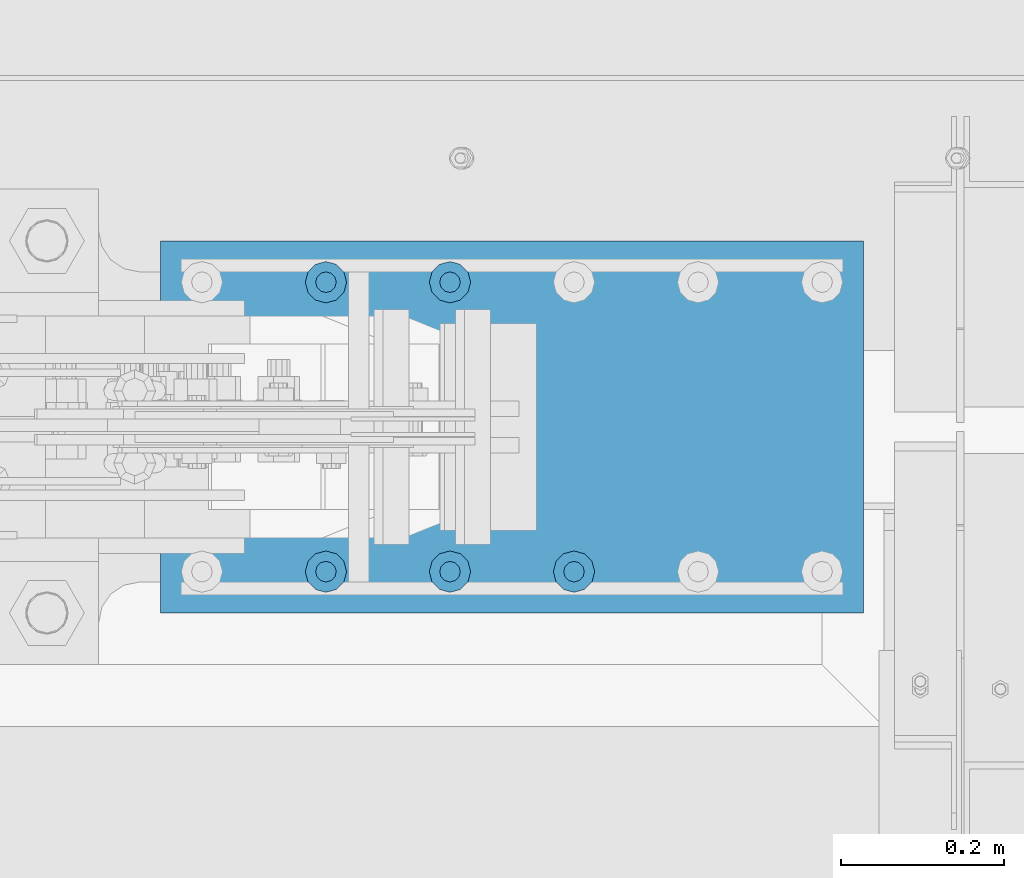
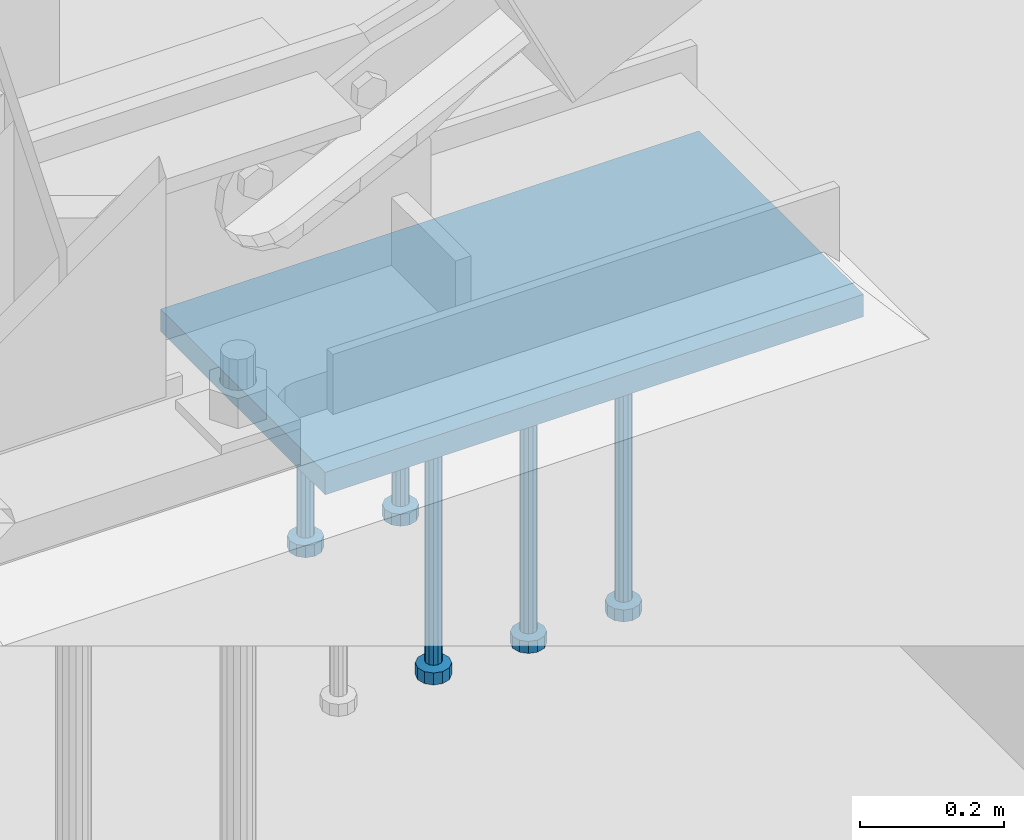
# One storey, part 890 of 1179: 6 beams, 1 element without a shape of its own.
"""IFC2X3 building model written with IfcOpenShell, lengths in millimetres."""

from ifc_helpers import new_model, si_unit, frame, origin_with_axes, place, context, subcontext, project, spatial, faceted_brep, material, type_object, element, aggregate, save


model = new_model("IFC2X3")

# Units and contexts
model_context = context("Model", 3, precision=1e-05, world=origin_with_axes())
body_context = subcontext(model_context, "Body", "Model", "MODEL_VIEW")
ifc_project = project(units=[si_unit("LENGTHUNIT", "METRE", prefix="MILLI"), si_unit("AREAUNIT", "SQUARE_METRE"), si_unit("VOLUMEUNIT", "CUBIC_METRE"), si_unit("MASSUNIT", "GRAM", prefix="KILO"), si_unit("TIMEUNIT", "SECOND"), si_unit("PLANEANGLEUNIT", "RADIAN"), si_unit("SOLIDANGLEUNIT", "STERADIAN"), si_unit("THERMODYNAMICTEMPERATUREUNIT", "DEGREE_CELSIUS"), si_unit("LUMINOUSINTENSITYUNIT", "LUMEN")], contexts=[model_context])

# Site, building, storey
site_placement = place(None, origin_with_axes())
site = spatial("IfcSite", under=ifc_project, at=site_placement, CompositionType="ELEMENT")
building_placement = place(site_placement, origin_with_axes())
building = spatial("IfcBuilding", under=site, at=building_placement, Name="Undefined", CompositionType="ELEMENT")
storey_placement = place(building_placement, origin_with_axes())
storey = spatial("IfcBuildingStorey", under=building, at=storey_placement, Name="Undefined", CompositionType="ELEMENT", Elevation=0.0)

# Assembly, beams
assembly_placement = place(storey_placement, origin_with_axes())
assembly = element("IfcElementAssembly", 1, at=assembly_placement, inside=storey, Name="EMBED_PLATE", AssemblyPlace="NOTDEFINED", PredefinedType="RIGID_FRAME")
ifc_material_1 = material(Name="STEEL/A108")
beam_type_1 = type_object("IfcBeamType", Name="STUD_1-DIA", PredefinedType="NOTDEFINED")
beam_1_placement = place(assembly_placement, frame((9004.3, 41376.6, -393.7), z_axis=(1.0, 0.0, 0.0), x_axis=(0.0, 0.0, -1.0)))
beam_1 = element("IfcBeam", 2, at=beam_1_placement, type_object=beam_type_1, material=ifc_material_1, Name="STUD", ObjectType="STUD_1-DIA", context=body_context, shape_type="Brep", body=[
    faceted_brep([(0.0, -12.7, 0.0), (0.0, -11.0, -6.34999990463257), (382.016, -11.0, -6.34999990463257), (382.016, -12.6999998092651, 0.0), (0.0, -6.34999990463257, -11.0), (382.016, -6.34999990463257, -11.0), (0.0, 0.0, -12.6999998092651), (382.016, 0.0, -12.6999998092651), (0.0, 6.34999990463257, -11.0), (382.016, 6.34999990463257, -11.0), (0.0, 11.0, -6.34999990463257), (382.016, 11.0, -6.34999990463257), (0.0, 12.7, 0.0), (382.016, 12.6999998092651, 0.0), (0.0, 11.0, 6.34999990463257), (382.016, 11.0, 6.34999990463257), (0.0, 6.34999990463257, 11.0), (382.016, 6.34999990463257, 11.0), (0.0, 0.0, 12.6999998092651), (382.016, 0.0, 12.6999998092651), (0.0, -6.34999990463257, 11.0), (382.016, -6.34999990463257, 11.0), (0.0, -11.0, 6.34999990463257), (382.016, -11.0, 6.34999990463257), (386.08, -22.0, -12.6999998092651), (386.08, -25.3999996185303, 0.0), (386.08, -12.6999998092651, -22.0), (386.08, 0.0, -25.3999996185303), (386.08, 12.6999998092651, -22.0), (386.08, 22.0, -12.6999998092651), (386.08, 25.3999996185303, 0.0), (386.08, 22.0, 12.6999998092651), (386.08, 12.6999998092651, 22.0), (386.08, 0.0, 25.3999996185303), (386.08, -12.6999998092651, 22.0), (386.08, -22.0, 12.6999998092651), (406.4, -22.0, -12.6999998092651), (406.4, -25.3999996185303, 0.0), (406.4, -12.6999998092651, -22.0), (406.4, 0.0, -25.3999996185303), (406.4, 12.6999998092651, -22.0), (406.4, 22.0, -12.6999998092651), (406.4, 25.3999996185303, 0.0), (406.4, 22.0, 12.6999998092651), (406.4, 12.6999998092651, 22.0), (406.4, 0.0, 25.3999996185303), (406.4, -12.6999998092651, 22.0), (406.4, -22.0, 12.6999998092651)], [[[0, 1, 2, 3]], [[1, 4, 5, 2]], [[4, 6, 7, 5]], [[6, 8, 9, 7]], [[8, 10, 11, 9]], [[10, 12, 13, 11]], [[12, 14, 15, 13]], [[14, 16, 17, 15]], [[16, 18, 19, 17]], [[18, 20, 21, 19]], [[20, 22, 23, 21]], [[22, 0, 3, 23]], [[22, 20, 18, 16, 14, 12, 10, 8, 6, 4, 1, 0]], [[3, 2, 24, 25]], [[2, 5, 26, 24]], [[5, 7, 27, 26]], [[7, 9, 28, 27]], [[9, 11, 29, 28]], [[11, 13, 30, 29]], [[13, 15, 31, 30]], [[15, 17, 32, 31]], [[17, 19, 33, 32]], [[19, 21, 34, 33]], [[21, 23, 35, 34]], [[23, 3, 25, 35]], [[25, 24, 36, 37]], [[24, 26, 38, 36]], [[26, 27, 39, 38]], [[27, 28, 40, 39]], [[28, 29, 41, 40]], [[29, 30, 42, 41]], [[30, 31, 43, 42]], [[31, 32, 44, 43]], [[32, 33, 45, 44]], [[33, 34, 46, 45]], [[34, 35, 47, 46]], [[35, 25, 37, 47]], [[38, 39, 40, 41, 42, 43, 44, 45, 46, 47, 37, 36]]]),
])
beam_2_placement = place(assembly_placement, frame((8851.9, 41376.6, -393.7), z_axis=(1.0, 0.0, 0.0), x_axis=(0.0, 0.0, -1.0)))
beam_2 = element("IfcBeam", 3, at=beam_2_placement, type_object=beam_type_1, material=ifc_material_1, Name="STUD", ObjectType="STUD_1-DIA", context=body_context, shape_type="Brep", body=[
    faceted_brep([(0.0, -12.7, 0.0), (0.0, -11.0, -6.34999990463257), (382.016, -11.0, -6.34999990463257), (382.016, -12.6999998092651, 0.0), (0.0, -6.34999990463257, -11.0), (382.016, -6.34999990463257, -11.0), (0.0, 0.0, -12.6999998092651), (382.016, 0.0, -12.6999998092651), (0.0, 6.34999990463257, -11.0), (382.016, 6.34999990463257, -11.0), (0.0, 11.0, -6.34999990463257), (382.016, 11.0, -6.34999990463257), (0.0, 12.7, 0.0), (382.016, 12.6999998092651, 0.0), (0.0, 11.0, 6.34999990463257), (382.016, 11.0, 6.34999990463257), (0.0, 6.34999990463257, 11.0), (382.016, 6.34999990463257, 11.0), (0.0, 0.0, 12.6999998092651), (382.016, 0.0, 12.6999998092651), (0.0, -6.34999990463257, 11.0), (382.016, -6.34999990463257, 11.0), (0.0, -11.0, 6.34999990463257), (382.016, -11.0, 6.34999990463257), (386.08, -22.0, -12.6999998092651), (386.08, -25.3999996185303, 0.0), (386.08, -12.6999998092651, -22.0), (386.08, 0.0, -25.3999996185303), (386.08, 12.6999998092651, -22.0), (386.08, 22.0, -12.6999998092651), (386.08, 25.3999996185303, 0.0), (386.08, 22.0, 12.6999998092651), (386.08, 12.6999998092651, 22.0), (386.08, 0.0, 25.3999996185303), (386.08, -12.6999998092651, 22.0), (386.08, -22.0, 12.6999998092651), (406.4, -22.0, -12.6999998092651), (406.4, -25.3999996185303, 0.0), (406.4, -12.6999998092651, -22.0), (406.4, 0.0, -25.3999996185303), (406.4, 12.6999998092651, -22.0), (406.4, 22.0, -12.6999998092651), (406.4, 25.3999996185303, 0.0), (406.4, 22.0, 12.6999998092651), (406.4, 12.6999998092651, 22.0), (406.4, 0.0, 25.3999996185303), (406.4, -12.6999998092651, 22.0), (406.4, -22.0, 12.6999998092651)], [[[0, 1, 2, 3]], [[1, 4, 5, 2]], [[4, 6, 7, 5]], [[6, 8, 9, 7]], [[8, 10, 11, 9]], [[10, 12, 13, 11]], [[12, 14, 15, 13]], [[14, 16, 17, 15]], [[16, 18, 19, 17]], [[18, 20, 21, 19]], [[20, 22, 23, 21]], [[22, 0, 3, 23]], [[22, 20, 18, 16, 14, 12, 10, 8, 6, 4, 1, 0]], [[3, 2, 24, 25]], [[2, 5, 26, 24]], [[5, 7, 27, 26]], [[7, 9, 28, 27]], [[9, 11, 29, 28]], [[11, 13, 30, 29]], [[13, 15, 31, 30]], [[15, 17, 32, 31]], [[17, 19, 33, 32]], [[19, 21, 34, 33]], [[21, 23, 35, 34]], [[23, 3, 25, 35]], [[25, 24, 36, 37]], [[24, 26, 38, 36]], [[26, 27, 39, 38]], [[27, 28, 40, 39]], [[28, 29, 41, 40]], [[29, 30, 42, 41]], [[30, 31, 43, 42]], [[31, 32, 44, 43]], [[32, 33, 45, 44]], [[33, 34, 46, 45]], [[34, 35, 47, 46]], [[35, 25, 37, 47]], [[38, 39, 40, 41, 42, 43, 44, 45, 46, 47, 37, 36]]]),
])
beam_3_placement = place(assembly_placement, frame((9156.7, 41021.0, -393.7), z_axis=(1.0, 0.0, 0.0), x_axis=(0.0, 0.0, -1.0)))
beam_3 = element("IfcBeam", 4, at=beam_3_placement, type_object=beam_type_1, material=ifc_material_1, Name="STUD", ObjectType="STUD_1-DIA", context=body_context, shape_type="Brep", body=[
    faceted_brep([(0.0, -12.7, 0.0), (0.0, -11.0, -6.34999990463257), (382.016, -11.0, -6.34999990463257), (382.016, -12.6999998092651, 0.0), (0.0, -6.34999990463257, -11.0), (382.016, -6.34999990463257, -11.0), (0.0, 0.0, -12.6999998092651), (382.016, 0.0, -12.6999998092651), (0.0, 6.34999990463257, -11.0), (382.016, 6.34999990463257, -11.0), (0.0, 11.0, -6.34999990463257), (382.016, 11.0, -6.34999990463257), (0.0, 12.7, 0.0), (382.016, 12.6999998092651, 0.0), (0.0, 11.0, 6.34999990463257), (382.016, 11.0, 6.34999990463257), (0.0, 6.34999990463257, 11.0), (382.016, 6.34999990463257, 11.0), (0.0, 0.0, 12.6999998092651), (382.016, 0.0, 12.6999998092651), (0.0, -6.34999990463257, 11.0), (382.016, -6.34999990463257, 11.0), (0.0, -11.0, 6.34999990463257), (382.016, -11.0, 6.34999990463257), (386.08, -22.0, -12.6999998092651), (386.08, -25.3999996185303, 0.0), (386.08, -12.6999998092651, -22.0), (386.08, 0.0, -25.3999996185303), (386.08, 12.6999998092651, -22.0), (386.08, 22.0, -12.6999998092651), (386.08, 25.3999996185303, 0.0), (386.08, 22.0, 12.6999998092651), (386.08, 12.6999998092651, 22.0), (386.08, 0.0, 25.3999996185303), (386.08, -12.6999998092651, 22.0), (386.08, -22.0, 12.6999998092651), (406.4, -22.0, -12.6999998092651), (406.4, -25.3999996185303, 0.0), (406.4, -12.6999998092651, -22.0), (406.4, 0.0, -25.3999996185303), (406.4, 12.6999998092651, -22.0), (406.4, 22.0, -12.6999998092651), (406.4, 25.3999996185303, 0.0), (406.4, 22.0, 12.6999998092651), (406.4, 12.6999998092651, 22.0), (406.4, 0.0, 25.3999996185303), (406.4, -12.6999998092651, 22.0), (406.4, -22.0, 12.6999998092651)], [[[0, 1, 2, 3]], [[1, 4, 5, 2]], [[4, 6, 7, 5]], [[6, 8, 9, 7]], [[8, 10, 11, 9]], [[10, 12, 13, 11]], [[12, 14, 15, 13]], [[14, 16, 17, 15]], [[16, 18, 19, 17]], [[18, 20, 21, 19]], [[20, 22, 23, 21]], [[22, 0, 3, 23]], [[22, 20, 18, 16, 14, 12, 10, 8, 6, 4, 1, 0]], [[3, 2, 24, 25]], [[2, 5, 26, 24]], [[5, 7, 27, 26]], [[7, 9, 28, 27]], [[9, 11, 29, 28]], [[11, 13, 30, 29]], [[13, 15, 31, 30]], [[15, 17, 32, 31]], [[17, 19, 33, 32]], [[19, 21, 34, 33]], [[21, 23, 35, 34]], [[23, 3, 25, 35]], [[25, 24, 36, 37]], [[24, 26, 38, 36]], [[26, 27, 39, 38]], [[27, 28, 40, 39]], [[28, 29, 41, 40]], [[29, 30, 42, 41]], [[30, 31, 43, 42]], [[31, 32, 44, 43]], [[32, 33, 45, 44]], [[33, 34, 46, 45]], [[34, 35, 47, 46]], [[35, 25, 37, 47]], [[38, 39, 40, 41, 42, 43, 44, 45, 46, 47, 37, 36]]]),
])
beam_4_placement = place(assembly_placement, frame((9004.3, 41021.0, -393.7), z_axis=(1.0, 0.0, 0.0), x_axis=(0.0, 0.0, -1.0)))
beam_4 = element("IfcBeam", 5, at=beam_4_placement, type_object=beam_type_1, material=ifc_material_1, Name="STUD", ObjectType="STUD_1-DIA", context=body_context, shape_type="Brep", body=[
    faceted_brep([(0.0, -12.7, 0.0), (0.0, -11.0, -6.34999990463257), (382.016, -11.0, -6.34999990463257), (382.016, -12.6999998092651, 0.0), (0.0, -6.34999990463257, -11.0), (382.016, -6.34999990463257, -11.0), (0.0, 0.0, -12.6999998092651), (382.016, 0.0, -12.6999998092651), (0.0, 6.34999990463257, -11.0), (382.016, 6.34999990463257, -11.0), (0.0, 11.0, -6.34999990463257), (382.016, 11.0, -6.34999990463257), (0.0, 12.7, 0.0), (382.016, 12.6999998092651, 0.0), (0.0, 11.0, 6.34999990463257), (382.016, 11.0, 6.34999990463257), (0.0, 6.34999990463257, 11.0), (382.016, 6.34999990463257, 11.0), (0.0, 0.0, 12.6999998092651), (382.016, 0.0, 12.6999998092651), (0.0, -6.34999990463257, 11.0), (382.016, -6.34999990463257, 11.0), (0.0, -11.0, 6.34999990463257), (382.016, -11.0, 6.34999990463257), (386.08, -22.0, -12.6999998092651), (386.08, -25.3999996185303, 0.0), (386.08, -12.6999998092651, -22.0), (386.08, 0.0, -25.3999996185303), (386.08, 12.6999998092651, -22.0), (386.08, 22.0, -12.6999998092651), (386.08, 25.3999996185303, 0.0), (386.08, 22.0, 12.6999998092651), (386.08, 12.6999998092651, 22.0), (386.08, 0.0, 25.3999996185303), (386.08, -12.6999998092651, 22.0), (386.08, -22.0, 12.6999998092651), (406.4, -22.0, -12.6999998092651), (406.4, -25.3999996185303, 0.0), (406.4, -12.6999998092651, -22.0), (406.4, 0.0, -25.3999996185303), (406.4, 12.6999998092651, -22.0), (406.4, 22.0, -12.6999998092651), (406.4, 25.3999996185303, 0.0), (406.4, 22.0, 12.6999998092651), (406.4, 12.6999998092651, 22.0), (406.4, 0.0, 25.3999996185303), (406.4, -12.6999998092651, 22.0), (406.4, -22.0, 12.6999998092651)], [[[0, 1, 2, 3]], [[1, 4, 5, 2]], [[4, 6, 7, 5]], [[6, 8, 9, 7]], [[8, 10, 11, 9]], [[10, 12, 13, 11]], [[12, 14, 15, 13]], [[14, 16, 17, 15]], [[16, 18, 19, 17]], [[18, 20, 21, 19]], [[20, 22, 23, 21]], [[22, 0, 3, 23]], [[22, 20, 18, 16, 14, 12, 10, 8, 6, 4, 1, 0]], [[3, 2, 24, 25]], [[2, 5, 26, 24]], [[5, 7, 27, 26]], [[7, 9, 28, 27]], [[9, 11, 29, 28]], [[11, 13, 30, 29]], [[13, 15, 31, 30]], [[15, 17, 32, 31]], [[17, 19, 33, 32]], [[19, 21, 34, 33]], [[21, 23, 35, 34]], [[23, 3, 25, 35]], [[25, 24, 36, 37]], [[24, 26, 38, 36]], [[26, 27, 39, 38]], [[27, 28, 40, 39]], [[28, 29, 41, 40]], [[29, 30, 42, 41]], [[30, 31, 43, 42]], [[31, 32, 44, 43]], [[32, 33, 45, 44]], [[33, 34, 46, 45]], [[34, 35, 47, 46]], [[35, 25, 37, 47]], [[38, 39, 40, 41, 42, 43, 44, 45, 46, 47, 37, 36]]]),
])
beam_5_placement = place(assembly_placement, frame((8851.9, 41021.0, -393.7), z_axis=(1.0, 0.0, 0.0), x_axis=(0.0, 0.0, -1.0)))
beam_5 = element("IfcBeam", 6, at=beam_5_placement, type_object=beam_type_1, material=ifc_material_1, Name="STUD", ObjectType="STUD_1-DIA", context=body_context, shape_type="Brep", body=[
    faceted_brep([(0.0, -12.7, 0.0), (0.0, -11.0, -6.34999990463257), (382.016, -11.0, -6.34999990463257), (382.016, -12.6999998092651, 0.0), (0.0, -6.34999990463257, -11.0), (382.016, -6.34999990463257, -11.0), (0.0, 0.0, -12.6999998092651), (382.016, 0.0, -12.6999998092651), (0.0, 6.34999990463257, -11.0), (382.016, 6.34999990463257, -11.0), (0.0, 11.0, -6.34999990463257), (382.016, 11.0, -6.34999990463257), (0.0, 12.7, 0.0), (382.016, 12.6999998092651, 0.0), (0.0, 11.0, 6.34999990463257), (382.016, 11.0, 6.34999990463257), (0.0, 6.34999990463257, 11.0), (382.016, 6.34999990463257, 11.0), (0.0, 0.0, 12.6999998092651), (382.016, 0.0, 12.6999998092651), (0.0, -6.34999990463257, 11.0), (382.016, -6.34999990463257, 11.0), (0.0, -11.0, 6.34999990463257), (382.016, -11.0, 6.34999990463257), (386.08, -22.0, -12.6999998092651), (386.08, -25.3999996185303, 0.0), (386.08, -12.6999998092651, -22.0), (386.08, 0.0, -25.3999996185303), (386.08, 12.6999998092651, -22.0), (386.08, 22.0, -12.6999998092651), (386.08, 25.3999996185303, 0.0), (386.08, 22.0, 12.6999998092651), (386.08, 12.6999998092651, 22.0), (386.08, 0.0, 25.3999996185303), (386.08, -12.6999998092651, 22.0), (386.08, -22.0, 12.6999998092651), (406.4, -22.0, -12.6999998092651), (406.4, -25.3999996185303, 0.0), (406.4, -12.6999998092651, -22.0), (406.4, 0.0, -25.3999996185303), (406.4, 12.6999998092651, -22.0), (406.4, 22.0, -12.6999998092651), (406.4, 25.3999996185303, 0.0), (406.4, 22.0, 12.6999998092651), (406.4, 12.6999998092651, 22.0), (406.4, 0.0, 25.3999996185303), (406.4, -12.6999998092651, 22.0), (406.4, -22.0, 12.6999998092651)], [[[0, 1, 2, 3]], [[1, 4, 5, 2]], [[4, 6, 7, 5]], [[6, 8, 9, 7]], [[8, 10, 11, 9]], [[10, 12, 13, 11]], [[12, 14, 15, 13]], [[14, 16, 17, 15]], [[16, 18, 19, 17]], [[18, 20, 21, 19]], [[20, 22, 23, 21]], [[22, 0, 3, 23]], [[22, 20, 18, 16, 14, 12, 10, 8, 6, 4, 1, 0]], [[3, 2, 24, 25]], [[2, 5, 26, 24]], [[5, 7, 27, 26]], [[7, 9, 28, 27]], [[9, 11, 29, 28]], [[11, 13, 30, 29]], [[13, 15, 31, 30]], [[15, 17, 32, 31]], [[17, 19, 33, 32]], [[19, 21, 34, 33]], [[21, 23, 35, 34]], [[23, 3, 25, 35]], [[25, 24, 36, 37]], [[24, 26, 38, 36]], [[26, 27, 39, 38]], [[27, 28, 40, 39]], [[28, 29, 41, 40]], [[29, 30, 42, 41]], [[30, 31, 43, 42]], [[31, 32, 44, 43]], [[32, 33, 45, 44]], [[33, 34, 46, 45]], [[34, 35, 47, 46]], [[35, 25, 37, 47]], [[38, 39, 40, 41, 42, 43, 44, 45, 46, 47, 37, 36]]]),
])
ifc_material_2 = material(Name="STEEL/A572-GR.50")
beam_type_2 = type_object("IfcBeamType", PredefinedType="NOTDEFINED")
beam_6_placement = place(assembly_placement, frame((8648.7, 41198.8, -374.65), z_axis=(0.0, 1.0, 0.0), x_axis=(1.0, 0.0, 0.0)))
beam_6 = element("IfcBeam", 7, at=beam_6_placement, type_object=beam_type_2, material=ifc_material_2, Name="EMBED_PLATE", context=body_context, shape_type="Brep", body=[
    faceted_brep([(0.0, 19.05, -228.6), (0.0, 19.05, 228.6), (863.599999999999, 19.05, 228.599999999999), (863.599999999999, 19.05, -228.599999999999), (0.0, -19.05, 228.6), (863.599999999999, -19.05, 228.599999999999), (0.0, -19.05, -228.6), (863.599999999999, -19.05, -228.599999999999)], [[[0, 1, 2, 3]], [[1, 4, 5, 2]], [[4, 6, 7, 5]], [[6, 0, 3, 7]], [[5, 7, 3, 2]], [[6, 4, 1, 0]]]),
])
aggregate(assembly, [beam_1, beam_2, beam_3, beam_4, beam_5, beam_6])

save(model, "model.ifc")
